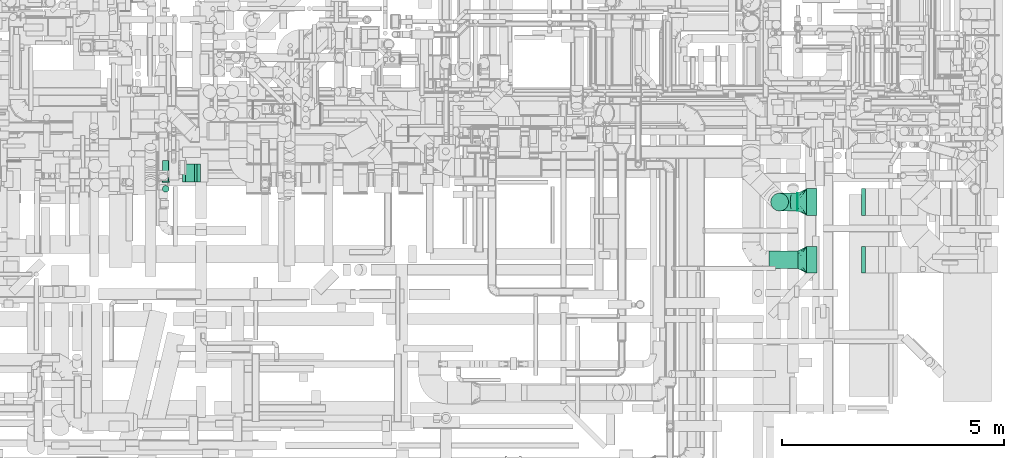
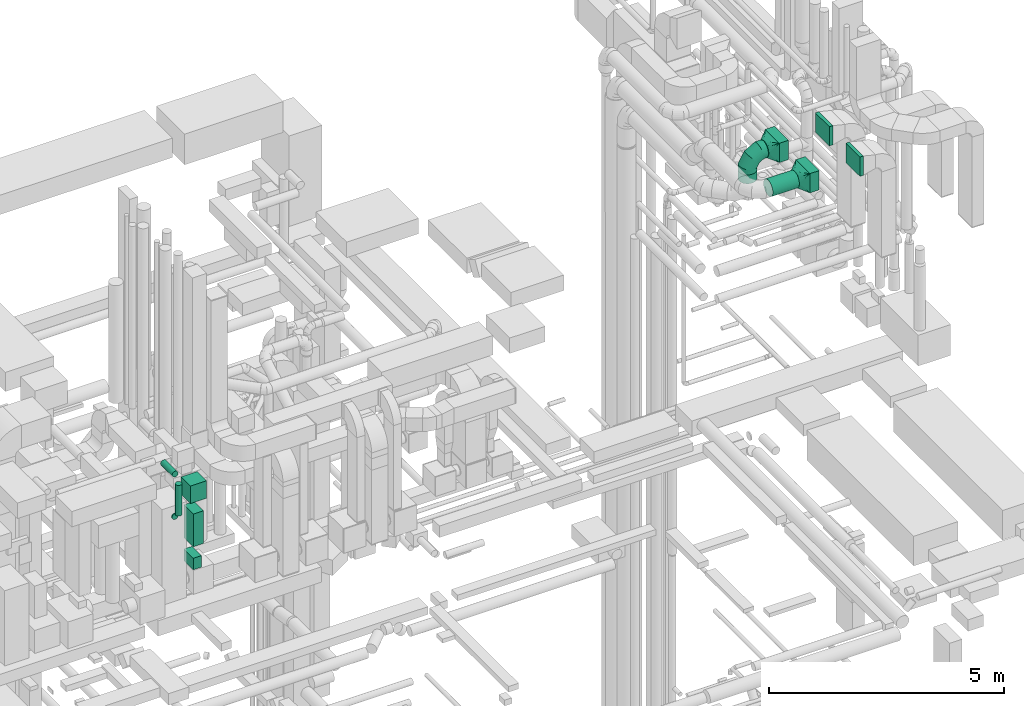
# One storey, part 219 of 337: 13 flow segments, 3 flow fittings.
"""IFC2X3 building model written with IfcOpenShell, lengths in millimetres."""

from ifc_helpers import new_model, entity, si_unit, converted_unit, derived_unit, direction, frame, origin, origin_2d_with_axis, place, context, subcontext, project, spatial, rectangle, circle, extrude, faceted_brep, source, transform, mapped, material, type_object, type_shapes, element, save


model = new_model("IFC2X3")

# Units and contexts
model_context = context("Model", 3, precision=0.01, world=origin(), true_north=direction((6.12303176911189e-17, 1.0)))
body_context = subcontext(model_context, "Body", "Model", "MODEL_VIEW")
ifc_project = project(units=[si_unit("LENGTHUNIT", "METRE", prefix="MILLI"), si_unit("AREAUNIT", "SQUARE_METRE"), si_unit("VOLUMEUNIT", "CUBIC_METRE"), converted_unit("PLANEANGLEUNIT", "DEGREE", entity("IfcRatioMeasure", 0.0174532925199433), si_unit("PLANEANGLEUNIT", "RADIAN"), dimensions=[0, 0, 0, 0, 0, 0, 0]), si_unit("MASSUNIT", "GRAM", prefix="KILO"), derived_unit("MASSDENSITYUNIT", [(si_unit("MASSUNIT", "GRAM", prefix="KILO"), 1), (si_unit("LENGTHUNIT", "METRE"), -3)]), derived_unit("MOMENTOFINERTIAUNIT", [(si_unit("LENGTHUNIT", "METRE"), 4)]), si_unit("TIMEUNIT", "SECOND"), si_unit("FREQUENCYUNIT", "HERTZ"), si_unit("THERMODYNAMICTEMPERATUREUNIT", "DEGREE_CELSIUS"), derived_unit("THERMALTRANSMITTANCEUNIT", [(si_unit("MASSUNIT", "GRAM", prefix="KILO"), 1), (si_unit("THERMODYNAMICTEMPERATUREUNIT", "KELVIN"), -1), (si_unit("TIMEUNIT", "SECOND"), -3)]), derived_unit("VOLUMETRICFLOWRATEUNIT", [(si_unit("LENGTHUNIT", "METRE"), 3), (si_unit("TIMEUNIT", "SECOND"), -1)]), derived_unit("MASSFLOWRATEUNIT", [(si_unit("MASSUNIT", "GRAM", prefix="KILO"), 1), (si_unit("TIMEUNIT", "SECOND"), -1)]), derived_unit("ROTATIONALFREQUENCYUNIT", [(si_unit("TIMEUNIT", "SECOND"), -1)]), si_unit("ELECTRICCURRENTUNIT", "AMPERE"), si_unit("ELECTRICVOLTAGEUNIT", "VOLT"), si_unit("POWERUNIT", "WATT"), si_unit("FORCEUNIT", "NEWTON", prefix="KILO"), si_unit("ILLUMINANCEUNIT", "LUX"), si_unit("LUMINOUSFLUXUNIT", "LUMEN"), si_unit("LUMINOUSINTENSITYUNIT", "CANDELA"), derived_unit("USERDEFINED", [(si_unit("MASSUNIT", "GRAM", prefix="KILO"), -1), (si_unit("LENGTHUNIT", "METRE"), -2), (si_unit("TIMEUNIT", "SECOND"), 3), (si_unit("LUMINOUSFLUXUNIT", "LUMEN"), 1)]), derived_unit("LINEARVELOCITYUNIT", [(si_unit("LENGTHUNIT", "METRE"), 1), (si_unit("TIMEUNIT", "SECOND"), -1)]), si_unit("PRESSUREUNIT", "PASCAL"), derived_unit("USERDEFINED", [(si_unit("LENGTHUNIT", "METRE"), -2), (si_unit("MASSUNIT", "GRAM", prefix="KILO"), 1), (si_unit("TIMEUNIT", "SECOND"), -2)]), derived_unit("LINEARFORCEUNIT", [(si_unit("MASSUNIT", "GRAM", prefix="KILO"), 1), (si_unit("LENGTHUNIT", "METRE"), 1), (si_unit("TIMEUNIT", "SECOND"), -2), (si_unit("LENGTHUNIT", "METRE"), -1)]), derived_unit("PLANARFORCEUNIT", [(si_unit("MASSUNIT", "GRAM", prefix="KILO"), 1), (si_unit("LENGTHUNIT", "METRE"), 1), (si_unit("TIMEUNIT", "SECOND"), -2), (si_unit("LENGTHUNIT", "METRE"), -2)])], contexts=[model_context])

# Site, building, storey
site_placement = place(None, origin())
site = spatial("IfcSite", under=ifc_project, at=site_placement, CompositionType="ELEMENT")
building_placement = place(site_placement, origin())
building = spatial("IfcBuilding", under=site, at=building_placement, CompositionType="ELEMENT")
storey_placement = place(building_placement, origin())
storey = spatial("IfcBuildingStorey", under=building, at=storey_placement, CompositionType="ELEMENT", Elevation=0.0)

# Flow segments
duct_segment_type_1 = type_object("IfcDuctSegmentType", PredefinedType="NOTDEFINED")
flow_segment_1_placement = place(storey_placement, frame((70039.84, 6153.72, 35300.0)))
element("IfcFlowSegment", 1, at=flow_segment_1_placement, inside=storey, type_object=duct_segment_type_1, context=body_context, shape_type="SweptSolid", body=[
    extrude(rectangle(XDim=87.0958234548722, YDim=600.0, at=origin_2d_with_axis()), frame((43.55, 300.0, 0.0), z_axis=(0.0, 0.0, 1.0), x_axis=(-1.0, 0.0, 0.0)), (0.0, 0.0, 1.0), 499.999999999999),
])
flow_segment_2_placement = place(storey_placement, frame((68809.84, 6153.72, 35300.0)))
element("IfcFlowSegment", 2, at=flow_segment_2_placement, inside=storey, type_object=duct_segment_type_1, context=body_context, shape_type="SweptSolid", body=[
    extrude(rectangle(XDim=230.000000000026, YDim=600.0, at=origin_2d_with_axis()), frame((115.0, 300.0, 0.0), z_axis=(0.0, 0.0, 1.0), x_axis=(-1.0, 0.0, 0.0)), (0.0, 0.0, 1.0), 499.999999999999),
])
flow_segment_3_placement = place(storey_placement, frame((70039.84, 7453.72, 35300.0)))
element("IfcFlowSegment", 3, at=flow_segment_3_placement, inside=storey, type_object=duct_segment_type_1, context=body_context, shape_type="SweptSolid", body=[
    extrude(rectangle(XDim=87.0958234548809, YDim=600.0, at=origin_2d_with_axis()), frame((43.55, 300.0, 0.0), z_axis=(0.0, 0.0, 1.0), x_axis=(-1.0, 0.0, 0.0)), (0.0, 0.0, 1.0), 499.999999999999),
])
flow_segment_4_placement = place(storey_placement, frame((68809.84, 7453.72, 35300.0)))
element("IfcFlowSegment", 4, at=flow_segment_4_placement, inside=storey, type_object=duct_segment_type_1, context=body_context, shape_type="SweptSolid", body=[
    extrude(rectangle(XDim=230.000000000026, YDim=600.0, at=origin_2d_with_axis()), frame((115.0, 300.0, 0.0), z_axis=(0.0, 0.0, 1.0), x_axis=(-1.0, 0.0, 0.0)), (0.0, 0.0, 1.0), 499.999999999999),
])
flow_segment_5_placement = place(storey_placement, frame((54838.0, 8207.5, 29152.0)))
element("IfcFlowSegment", 5, at=flow_segment_5_placement, inside=storey, type_object=duct_segment_type_1, context=body_context, shape_type="SweptSolid", body=[
    extrude(rectangle(XDim=200.000000000007, YDim=400.0, at=origin_2d_with_axis()), frame((100.0, 200.0, 0.0), z_axis=(0.0, 0.0, 1.0), x_axis=(-1.0, 0.0, 0.0)), (0.0, 0.0, 1.0), 297.000000001202),
])
flow_segment_6_placement = place(storey_placement, frame((54768.0, 8207.5, 30897.87)))
element("IfcFlowSegment", 6, at=flow_segment_6_placement, inside=storey, type_object=duct_segment_type_1, context=body_context, shape_type="SweptSolid", body=[
    extrude(rectangle(XDim=399.999999999999, YDim=399.999999999996, at=origin_2d_with_axis()), frame((200.0, 200.0, 0.0), z_axis=(0.0, 0.0, 1.0), x_axis=(0.0, -1.0, 0.0)), (0.0, 0.0, 1.0), 452.126419060234),
])
flow_segment_7_placement = place(storey_placement, frame((54838.0, 8207.5, 29749.0)))
element("IfcFlowSegment", 7, at=flow_segment_7_placement, inside=storey, type_object=duct_segment_type_1, context=body_context, shape_type="SweptSolid", body=[
    extrude(rectangle(XDim=249.999999999995, YDim=400.0, at=origin_2d_with_axis()), frame((125.0, 200.0, 0.0), z_axis=(0.0, 0.0, 1.0), x_axis=(-1.0, 0.0, 0.0)), (0.0, 0.0, 1.0), 848.873605940204),
])
duct_segment_type_2 = type_object("IfcDuctSegmentType", PredefinedType="NOTDEFINED")
flow_segment_8_placement = place(storey_placement, frame((67959.05, 6252.13, 35348.4)))
element("IfcFlowSegment", 8, at=flow_segment_8_placement, inside=storey, type_object=duct_segment_type_2, context=body_context, shape_type="SweptSolid", body=[
    extrude(circle(Radius=200.0, at=origin_2d_with_axis()), frame((0.0, 201.6, 201.6), z_axis=(1.0, 0.0, 0.0), x_axis=(0.0, 1.0, 0.0)), (0.0, 0.0, 1.0), 650.783986766627),
])
flow_segment_9_placement = place(storey_placement, frame((68599.84, 7552.13, 35348.4)))
element("IfcFlowSegment", 9, at=flow_segment_9_placement, inside=storey, type_object=duct_segment_type_2, context=body_context, shape_type="SweptSolid", body=[
    extrude(circle(Radius=200.0, at=origin_2d_with_axis()), frame((0.0, 201.6, 201.6), z_axis=(1.0, 0.0, 0.0), x_axis=(0.0, -1.0, 0.0)), (0.0, 0.0, 1.0), 9.99999999999773),
])
flow_segment_10_placement = place(storey_placement, frame((67998.24, 7552.13, 34920.0)))
element("IfcFlowSegment", 10, at=flow_segment_10_placement, inside=storey, type_object=duct_segment_type_2, context=body_context, shape_type="SweptSolid", body=[
    extrude(circle(Radius=200.0, at=origin_2d_with_axis()), frame((201.6, 201.6, 0.0), z_axis=(0.0, 0.0, 1.0), x_axis=(0.0, -1.0, 0.0)), (0.0, 0.0, 1.0), 230.0),
])
flow_segment_11_placement = place(storey_placement, frame((54311.4, 8199.5, 30623.4)))
element("IfcFlowSegment", 11, at=flow_segment_11_placement, inside=storey, type_object=duct_segment_type_2, context=body_context, shape_type="SweptSolid", body=[
    extrude(circle(Radius=75.0, at=origin_2d_with_axis()), frame((76.6, 0.0, 76.6), z_axis=(0.0, 1.0, 0.0), x_axis=(-1.0, 0.0, 0.0)), (0.0, 0.0, 1.0), 26.0000250001432),
])
flow_segment_12_placement = place(storey_placement, frame((54311.4, 7972.9, 30850.0)))
element("IfcFlowSegment", 12, at=flow_segment_12_placement, inside=storey, type_object=duct_segment_type_2, context=body_context, shape_type="SweptSolid", body=[
    extrude(circle(Radius=75.0, at=origin_2d_with_axis()), frame((76.6, 76.6, 0.0), z_axis=(0.0, 0.0, 1.0), x_axis=(-1.0, 0.0, 0.0)), (0.0, 0.0, 1.0), 800.0),
])
flow_segment_13_placement = place(storey_placement, frame((54311.4, 8199.5, 31723.4)))
element("IfcFlowSegment", 13, at=flow_segment_13_placement, inside=storey, type_object=duct_segment_type_2, context=body_context, shape_type="SweptSolid", body=[
    extrude(circle(Radius=75.0, at=origin_2d_with_axis()), frame((76.6, 0.0, 76.6), z_axis=(0.0, 1.0, 0.0), x_axis=(1.0, 0.0, 0.0)), (0.0, 0.0, 1.0), 491.00002500027),
])

# Flow fittings
ifc_material = material()
duct_fitting_type_1 = type_object("IfcDuctFittingType", PredefinedType="NOTDEFINED", material=ifc_material)
shared_shape_1 = source(origin(), body_context, "Body", "Brep", [
    faceted_brep([(-400.0, 0.0, -200.0), (-400.0, -44.5, -194.99), (-400.0, -86.78, -180.19), (-400.0, -124.7, -156.37), (-400.0, -156.37, -124.7), (-400.0, -180.19, -86.78), (-400.0, -194.99, -44.5), (-400.0, -200.0, 0.0), (-400.0, -194.99, 44.5), (-400.0, -180.19, 86.78), (-400.0, -156.37, 124.7), (-400.0, -124.7, 156.37), (-400.0, -86.78, 180.19), (-400.0, -44.5, 194.99), (-400.0, 0.0, 200.0), (-400.0, 44.5, 194.99), (-400.0, 86.78, 180.19), (-400.0, 124.7, 156.37), (-400.0, 156.37, 124.7), (-400.0, 180.19, 86.78), (-400.0, 194.99, 44.5), (-400.0, 200.0, 0.0), (-400.0, 194.99, -44.5), (-400.0, 180.19, -86.78), (-400.0, 156.37, -124.7), (-400.0, 124.7, -156.37), (-400.0, 86.78, -180.19), (-400.0, 44.5, -194.99), (-292.82, 0.0, 200.0), (-304.75, 44.5, 194.99), (-316.07, 86.78, 180.19), (-326.23, 124.7, 156.37), (-334.72, 156.37, 124.7), (-341.1, 180.19, 86.78), (-345.07, 194.99, 44.5), (-346.41, 200.0, 0.0), (-345.07, 194.99, -44.5), (-341.1, 180.19, -86.78), (-334.72, 156.37, -124.7), (-326.23, 124.7, -156.37), (-316.07, 86.78, -180.19), (-304.75, 44.5, -194.99), (-292.82, 0.0, -200.0), (-280.9, -44.5, -194.99), (-269.57, -86.78, -180.19), (-259.41, -124.7, -156.37), (-250.92, -156.37, -124.7), (-244.54, -180.19, -86.78), (-240.57, -194.99, -44.5), (-239.23, -200.0, 0.0), (-240.57, -194.99, 44.5), (-244.54, -180.19, 86.78), (-250.92, -156.37, 124.7), (-259.41, -124.7, 156.37), (-269.57, -86.78, 180.19), (-280.9, -44.5, 194.99), (-107.18, 107.18, 200.0), (-139.76, 139.76, 194.99), (-170.7, 170.7, 180.19), (-198.46, 198.46, 156.37), (-221.65, 221.65, 124.7), (-239.09, 239.09, 86.78), (-249.92, 249.92, 44.5), (-253.59, 253.59, 0.0), (-249.92, 249.92, -44.5), (-239.09, 239.09, -86.78), (-221.65, 221.65, -124.7), (-198.46, 198.46, -156.37), (-170.7, 170.7, -180.19), (-139.76, 139.76, -194.99), (-107.18, 107.18, -200.0), (-74.6, 74.6, -194.99), (-43.65, 43.65, -180.19), (-15.89, 15.89, -156.37), (7.29, -7.29, -124.7), (24.73, -24.73, -86.78), (35.56, -35.56, -44.5), (39.23, -39.23, 0.0), (35.56, -35.56, 44.5), (24.73, -24.73, 86.78), (7.29, -7.29, 124.7), (-15.89, 15.89, 156.37), (-43.65, 43.65, 180.19), (-74.6, 74.6, 194.99), (0.0, 292.82, 200.0), (-44.5, 304.75, 194.99), (-86.78, 316.07, 180.19), (-124.7, 326.23, 156.37), (-156.37, 334.72, 124.7), (-180.19, 341.1, 86.78), (-194.99, 345.07, 44.5), (-200.0, 346.41, 0.0), (-194.99, 345.07, -44.5), (-180.19, 341.1, -86.78), (-156.37, 334.72, -124.7), (-124.7, 326.23, -156.37), (-86.78, 316.07, -180.19), (-44.5, 304.75, -194.99), (0.0, 292.82, -200.0), (44.5, 280.9, -194.99), (86.78, 269.57, -180.19), (124.7, 259.41, -156.37), (156.37, 250.92, -124.7), (180.19, 244.54, -86.78), (194.99, 240.57, -44.5), (200.0, 239.23, 0.0), (194.99, 240.57, 44.5), (180.19, 244.54, 86.78), (156.37, 250.92, 124.7), (124.7, 259.41, 156.37), (86.78, 269.57, 180.19), (44.5, 280.9, 194.99), (-44.5, 400.0, -194.99), (-86.78, 400.0, -180.19), (-124.7, 400.0, -156.37), (-156.37, 400.0, -124.7), (-180.19, 400.0, -86.78), (-194.99, 400.0, -44.5), (-200.0, 400.0, 0.0), (-194.99, 400.0, 44.5), (-180.19, 400.0, 86.78), (-156.37, 400.0, 124.7), (-124.7, 400.0, 156.37), (-86.78, 400.0, 180.19), (-44.5, 400.0, 194.99), (0.0, 400.0, 200.0), (44.5, 400.0, 194.99), (86.78, 400.0, 180.19), (124.7, 400.0, 156.37), (156.37, 400.0, 124.7), (180.19, 400.0, 86.78), (194.99, 400.0, 44.5), (200.0, 400.0, 0.0), (194.99, 400.0, -44.5), (180.19, 400.0, -86.78), (156.37, 400.0, -124.7), (124.7, 400.0, -156.37), (86.78, 400.0, -180.19), (44.5, 400.0, -194.99), (0.0, 400.0, -200.0)], [[[0, 1, 2, 3, 4, 5, 6, 7, 8, 9, 10, 11, 12, 13, 14, 15, 16, 17, 18, 19, 20, 21, 22, 23, 24, 25, 26, 27]], [[28, 29, 15, 14]], [[30, 31, 17, 16]], [[29, 30, 16, 15]], [[31, 32, 18, 17]], [[32, 33, 19, 18]], [[34, 35, 21, 20]], [[33, 34, 20, 19]], [[35, 36, 22, 21]], [[37, 38, 24, 23]], [[36, 37, 23, 22]], [[38, 39, 25, 24]], [[39, 40, 26, 25]], [[41, 42, 0, 27]], [[40, 41, 27, 26]], [[1, 0, 42, 43]], [[43, 44, 2, 1]], [[45, 3, 2, 44]], [[45, 46, 4, 3]], [[5, 4, 46, 47]], [[47, 48, 6, 5]], [[49, 7, 6, 48]], [[7, 49, 50, 8]], [[8, 50, 51, 9]], [[9, 51, 52, 10]], [[52, 53, 11, 10]], [[11, 53, 54, 12]], [[12, 54, 55, 13]], [[13, 55, 28, 14]], [[56, 57, 29, 28]], [[58, 59, 31, 30]], [[57, 58, 30, 29]], [[59, 60, 32, 31]], [[60, 61, 33, 32]], [[62, 63, 35, 34]], [[61, 62, 34, 33]], [[63, 64, 36, 35]], [[65, 66, 38, 37]], [[64, 65, 37, 36]], [[66, 67, 39, 38]], [[67, 68, 40, 39]], [[69, 70, 42, 41]], [[68, 69, 41, 40]], [[43, 42, 70, 71]], [[71, 72, 44, 43]], [[73, 45, 44, 72]], [[73, 74, 46, 45]], [[47, 46, 74, 75]], [[75, 76, 48, 47]], [[77, 49, 48, 76]], [[50, 49, 77, 78]], [[51, 50, 78, 79]], [[52, 51, 79, 80]], [[80, 81, 53, 52]], [[54, 53, 81, 82]], [[55, 54, 82, 83]], [[28, 55, 83, 56]], [[84, 85, 57, 56]], [[86, 87, 59, 58]], [[85, 86, 58, 57]], [[87, 88, 60, 59]], [[88, 89, 61, 60]], [[90, 91, 63, 62]], [[89, 90, 62, 61]], [[91, 92, 64, 63]], [[93, 94, 66, 65]], [[92, 93, 65, 64]], [[94, 95, 67, 66]], [[95, 96, 68, 67]], [[97, 98, 70, 69]], [[96, 97, 69, 68]], [[71, 70, 98, 99]], [[99, 100, 72, 71]], [[101, 73, 72, 100]], [[101, 102, 74, 73]], [[75, 74, 102, 103]], [[103, 104, 76, 75]], [[105, 77, 76, 104]], [[78, 77, 105, 106]], [[79, 78, 106, 107]], [[80, 79, 107, 108]], [[108, 109, 81, 80]], [[82, 81, 109, 110]], [[83, 82, 110, 111]], [[56, 83, 111, 84]], [[112, 113, 114, 115, 116, 117, 118, 119, 120, 121, 122, 123, 124, 125, 126, 127, 128, 129, 130, 131, 132, 133, 134, 135, 136, 137, 138, 139]], [[85, 84, 125, 124]], [[86, 85, 124, 123]], [[87, 86, 123, 122]], [[122, 121, 88, 87]], [[89, 88, 121, 120]], [[90, 89, 120, 119]], [[91, 90, 119, 118]], [[91, 118, 117, 92]], [[92, 117, 116, 93]], [[93, 116, 115, 94]], [[115, 114, 95, 94]], [[95, 114, 113, 96]], [[96, 113, 112, 97]], [[97, 112, 139, 98]], [[98, 139, 138, 99]], [[99, 138, 137, 100]], [[100, 137, 136, 101]], [[136, 135, 102, 101]], [[102, 135, 134, 103]], [[103, 134, 133, 104]], [[104, 133, 132, 105]], [[106, 105, 132, 131]], [[107, 106, 131, 130]], [[108, 107, 130, 129]], [[129, 128, 109, 108]], [[110, 109, 128, 127]], [[111, 110, 127, 126]], [[84, 111, 126, 125]]]),
])
type_shapes(duct_fitting_type_1, [shared_shape_1])
flow_fitting_placement = place(storey_placement, frame((68199.84, 7753.72, 35550.0), z_axis=(0.0, 1.0, 0.0), x_axis=(0.0, 0.0, 1.0)))
element("IfcFlowFitting", 14, at=flow_fitting_placement, inside=storey, type_object=duct_fitting_type_1, material=ifc_material, context=body_context, shape_type="MappedRepresentation", body=[
    mapped(shared_shape_1, transform((0.0, 0.0, 0.0), scale=1.0)),
])
duct_fitting_type_2 = type_object("IfcDuctFittingType", PredefinedType="NOTDEFINED", material=ifc_material)
shared_shape_2 = source(origin(), body_context, "Body", "Brep", [
    faceted_brep([(200.0, 44.5, 194.99), (200.0, 31.87, 196.41), (200.0, 19.23, 197.83), (200.0, 0.0, 200.0), (200.0, -19.23, 197.83), (200.0, -31.87, 196.41), (200.0, -44.5, 194.99), (200.0, -65.64, 187.59), (200.0, -86.78, 180.19), (200.0, -105.74, 168.28), (200.0, -124.7, 156.37), (200.0, -140.53, 140.53), (200.0, -156.37, 124.7), (200.0, -168.28, 105.74), (200.0, -180.19, 86.78), (200.0, -187.59, 65.64), (200.0, -194.99, 44.5), (200.0, -196.41, 31.87), (200.0, -197.83, 19.23), (200.0, -200.0, 0.0), (200.0, -197.83, -19.23), (200.0, -196.41, -31.87), (200.0, -194.99, -44.5), (200.0, -187.59, -65.64), (200.0, -180.19, -86.78), (200.0, -168.28, -105.74), (200.0, -156.37, -124.7), (200.0, -140.53, -140.53), (200.0, -124.7, -156.37), (200.0, -105.74, -168.28), (200.0, -86.78, -180.19), (200.0, -65.64, -187.59), (200.0, -44.5, -194.99), (200.0, -31.87, -196.41), (200.0, -19.23, -197.83), (200.0, 0.0, -200.0), (200.0, 19.23, -197.83), (200.0, 31.87, -196.41), (200.0, 44.5, -194.99), (200.0, 65.64, -187.59), (200.0, 86.78, -180.19), (200.0, 105.74, -168.28), (200.0, 124.7, -156.37), (200.0, 140.53, -140.53), (200.0, 156.37, -124.7), (200.0, 168.28, -105.74), (200.0, 180.19, -86.78), (200.0, 187.59, -65.64), (200.0, 194.99, -44.5), (200.0, 196.41, -31.87), (200.0, 197.83, -19.23), (200.0, 200.0, 0.0), (200.0, 197.83, 19.23), (200.0, 196.41, 31.87), (200.0, 194.99, 44.5), (200.0, 187.59, 65.64), (200.0, 180.19, 86.78), (200.0, 168.28, 105.74), (200.0, 156.37, 124.7), (200.0, 140.53, 140.53), (200.0, 124.7, 156.37), (200.0, 105.74, 168.28), (200.0, 86.78, 180.19), (200.0, 65.64, 187.59), (0.0, -300.0, 250.0), (0.0, 300.0, 250.0), (0.0, 300.0, -250.0), (0.0, -300.0, -250.0), (128.09, -235.96, 89.89), (104.11, -247.94, 119.86), (78.09, -182.87, 230.48), (52.06, -221.91, 236.99), (152.06, -223.97, 59.93), (164.04, -217.98, 44.95), (176.03, -211.99, 29.96), (128.09, -107.87, 217.98), (164.04, -53.94, 208.99), (152.06, -71.91, 211.99), (176.03, -35.96, 205.99), (26.03, -286.99, 217.46), (100.0, -216.3, 199.86), (26.03, -260.96, 243.49), (52.06, -273.97, 184.93), (104.11, -143.83, 223.97), (78.09, -260.96, 152.39), (26.03, -286.99, -217.46), (52.06, -273.97, -184.93), (78.09, -260.96, -152.39), (104.11, -247.94, -119.86), (128.09, -235.96, -89.89), (152.06, -223.97, -59.93), (164.04, -217.98, -44.95), (176.03, -211.99, -29.96), (128.09, -107.87, -217.98), (104.11, -143.83, -223.97), (152.06, -71.91, -211.99), (164.04, -53.94, -208.99), (176.03, -35.96, -205.99), (26.03, -260.96, -243.49), (100.0, -224.86, -191.3), (52.06, -221.91, -236.99), (78.09, -182.87, -230.48), (26.03, 260.96, -243.49), (52.06, 221.91, -236.99), (78.09, 182.87, -230.48), (104.11, 143.83, -223.97), (128.09, 107.87, -217.98), (152.06, 71.91, -211.99), (164.04, 53.94, -208.99), (176.03, 35.96, -205.99), (128.09, 235.96, -89.89), (104.11, 247.94, -119.86), (152.06, 223.97, -59.93), (164.04, 217.98, -44.95), (176.03, 211.99, -29.96), (26.03, 286.99, -217.46), (100.0, 216.3, -199.86), (52.06, 273.97, -184.93), (78.09, 260.96, -152.39), (26.03, 286.99, 217.46), (52.06, 273.97, 184.93), (78.09, 260.96, 152.39), (104.11, 247.94, 119.86), (128.09, 235.96, 89.89), (152.06, 223.97, 59.93), (164.04, 217.98, 44.95), (176.03, 211.99, 29.96), (128.09, 107.87, 217.98), (104.11, 143.83, 223.97), (152.06, 71.91, 211.99), (164.04, 53.94, 208.99), (176.03, 35.96, 205.99), (26.03, 260.96, 243.49), (100.0, 224.86, 191.3), (52.06, 221.91, 236.99), (78.09, 182.87, 230.48)], [[[0, 1, 2, 3, 4, 5, 6, 7, 8, 9, 10, 11, 12, 13, 14, 15, 16, 17, 18, 19, 20, 21, 22, 23, 24, 25, 26, 27, 28, 29, 30, 31, 32, 33, 34, 35, 36, 37, 38, 39, 40, 41, 42, 43, 44, 45, 46, 47, 48, 49, 50, 51, 52, 53, 54, 55, 56, 57, 58, 59, 60, 61, 62, 63]], [[64, 65, 66, 67]], [[68, 15, 69]], [[9, 70, 71]], [[16, 68, 72, 73, 74, 19, 18, 17]], [[6, 75, 7]], [[76, 77, 75, 6, 5, 4, 3, 78]], [[79, 12, 80]], [[80, 12, 11, 10]], [[10, 71, 81]], [[79, 82, 12]], [[8, 70, 9]], [[69, 15, 14]], [[83, 8, 7]], [[83, 7, 75]], [[68, 16, 15]], [[8, 83, 70]], [[84, 13, 82]], [[84, 69, 14]], [[64, 80, 81]], [[81, 80, 10]], [[79, 80, 64]], [[71, 10, 9]], [[13, 84, 14]], [[13, 12, 82]], [[74, 73, 72, 68, 69, 84, 82, 79, 64, 67, 85, 86, 87, 88, 89, 90, 91, 92, 19]], [[93, 31, 94]], [[25, 87, 86]], [[32, 93, 95, 96, 97, 35, 34, 33]], [[22, 89, 23]], [[91, 90, 89, 22, 21, 20, 19, 92]], [[98, 28, 99]], [[99, 28, 27, 26]], [[26, 86, 85]], [[98, 100, 28]], [[24, 87, 25]], [[94, 31, 30]], [[88, 24, 23]], [[88, 23, 89]], [[93, 32, 31]], [[24, 88, 87]], [[101, 29, 100]], [[101, 94, 30]], [[67, 99, 85]], [[85, 99, 26]], [[98, 99, 67]], [[86, 26, 25]], [[29, 101, 30]], [[29, 28, 100]], [[97, 96, 95, 93, 94, 101, 100, 98, 67, 66, 102, 103, 104, 105, 106, 107, 108, 109, 35]], [[110, 47, 111]], [[41, 104, 103]], [[48, 110, 112, 113, 114, 51, 50, 49]], [[38, 106, 39]], [[108, 107, 106, 38, 37, 36, 35, 109]], [[115, 44, 116]], [[116, 44, 43, 42]], [[42, 103, 102]], [[115, 117, 44]], [[40, 104, 41]], [[111, 47, 46]], [[105, 40, 39]], [[105, 39, 106]], [[110, 48, 47]], [[40, 105, 104]], [[118, 45, 117]], [[118, 111, 46]], [[66, 116, 102]], [[102, 116, 42]], [[115, 116, 66]], [[103, 42, 41]], [[45, 118, 46]], [[45, 44, 117]], [[66, 65, 119, 120, 121, 122, 123, 124, 125, 126, 51, 114, 113, 112, 110, 111, 118, 117, 115]], [[127, 63, 128]], [[57, 121, 120]], [[0, 127, 129, 130, 131, 3, 2, 1]], [[54, 123, 55]], [[125, 124, 123, 54, 53, 52, 51, 126]], [[132, 60, 133]], [[133, 60, 59, 58]], [[58, 120, 119]], [[132, 134, 60]], [[56, 121, 57]], [[128, 63, 62]], [[122, 56, 55]], [[122, 55, 123]], [[127, 0, 63]], [[56, 122, 121]], [[135, 61, 134]], [[135, 128, 62]], [[65, 133, 119]], [[119, 133, 58]], [[132, 133, 65]], [[120, 58, 57]], [[61, 135, 62]], [[61, 60, 134]], [[65, 64, 81, 71, 70, 83, 75, 77, 76, 78, 3, 131, 130, 129, 127, 128, 135, 134, 132]]]),
])
type_shapes(duct_fitting_type_2, [shared_shape_2])
for number, where, z_axis, x_axis in (
    (15, (68809.84, 6453.72, 35550.0), (0.0, 0.0, 1.0), (-1.0, 0.0, 0.0)),
    (16, (68809.84, 7753.72, 35550.0), (0.0, 0.0, 1.0), (-1.0, 0.0, 0.0)),
):
    element("IfcFlowFitting", number, at=place(storey_placement, frame(where, z_axis=z_axis, x_axis=x_axis)), inside=storey, type_object=duct_fitting_type_2, material=ifc_material, context=body_context, shape_type="MappedRepresentation", body=[
        mapped(shared_shape_2, transform((0.0, 0.0, 0.0), scale=1.0)),
    ])

save(model, "model.ifc")
